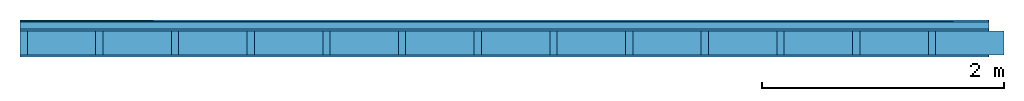
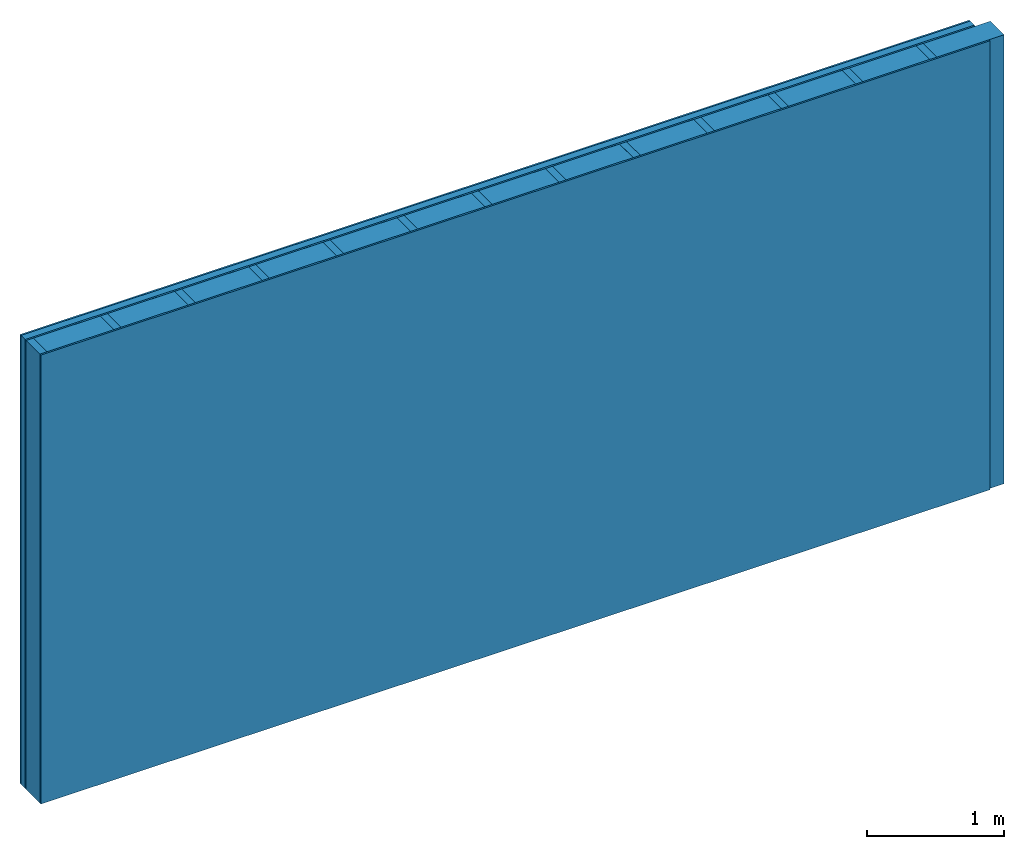
# One storey: 4 plates, 2 members, 1 element without a shape of its own.
"""IFC4 building model written with IfcOpenShell, lengths in metres."""

from ifc_helpers import new_model, si_unit, derived_unit, direction, frame, frame_2d, origin, origin_with_axes, place, context, project, spatial, rectangle, extrude, material, layer, layer_set, type_object, element, aggregate, save


model = new_model("IFC4")

# Units and contexts
plan_context = context("Plan", 3, precision=1e-05, world=origin(), true_north=direction((0.0, 1.0)))
model_context = context("Model", 3, precision=1e-05, world=origin(), true_north=direction((0.0, 1.0)))
ifc_project = project(units=[si_unit("LENGTHUNIT", "METRE"), derived_unit("SOUNDPRESSUREUNIT", [(si_unit("PRESSUREUNIT", "PASCAL", prefix="MICRO"), 0)]), si_unit("ENERGYUNIT", "JOULE", prefix="MEGA"), si_unit("MASSUNIT", "GRAM", prefix="KILO"), derived_unit("THERMALTRANSMITTANCEUNIT", [(si_unit("POWERUNIT", "WATT"), 1), (si_unit("AREAUNIT", "SQUARE_METRE"), -1), (si_unit("THERMODYNAMICTEMPERATUREUNIT", "KELVIN"), -1)]), derived_unit("AREADENSITYUNIT", [(si_unit("MASSUNIT", "GRAM", prefix="KILO"), 1), (si_unit("AREAUNIT", "SQUARE_METRE"), -1)]), derived_unit("USERDEFINED", [(si_unit("ENERGYUNIT", "JOULE", prefix="MEGA"), 1), (si_unit("AREAUNIT", "SQUARE_METRE"), -1)])], contexts=[plan_context, model_context])

# Site, building, storey
site = spatial("IfcSite", under=ifc_project)
building_placement = place(None, origin())
building = spatial("IfcBuilding", under=site, at=building_placement)
storey_placement = place(building_placement, origin())
storey = spatial("IfcBuildingStorey", under=building, at=storey_placement)

# Wall, members, plates
ifc_material_1 = material(Category="04.011")
ifc_layer_1 = layer(ifc_material_1, 0.015, Name="Surface 1")
ifc_material_2 = material(Category="10.008")
ifc_layer_2 = layer(ifc_material_2, 0.06, Name="outside 2nd layer")
ifc_material_3 = material(Category="03.007")
ifc_layer_3 = layer(ifc_material_3, 0.015, Name="outside 1st layer")
ifc_material_4 = material(Name="of the art")
ifc_layer_4 = layer(ifc_material_4, 0.0, Name="Bond")
ifc_layer_5 = layer(None, 0.2, Name="Support")
ifc_layer_6 = layer(ifc_material_4, 0.0, Name="Bond")
ifc_layer_7 = layer(ifc_material_3, 0.015, Name="1st layer")
ifc_material_5 = material(Name="Glued joints")
ifc_layer_8 = layer(ifc_material_5, 0.0, Name="Surface")
ifc_layer_set = layer_set([ifc_layer_1, ifc_layer_2, ifc_layer_3, ifc_layer_4, ifc_layer_5, ifc_layer_6, ifc_layer_7, ifc_layer_8])
wall_type = type_object("IfcWallType", Name="D0459", PredefinedType="NOTDEFINED", material=ifc_layer_set)
wall_placement = place(None, frame((0.0, 0.0, 0.0), z_axis=(0.0, -1.0, 0.0), x_axis=(1.0, 0.0, 0.0)))
wall = element("IfcWall", 1, at=wall_placement, inside=storey, type_object=wall_type, material=ifc_layer_set, Name="Wall #1")
ifc_material_6 = material()
member_1_placement = place(wall_placement, origin())
member_1 = element("IfcMember", 2, at=member_1_placement, material=ifc_material_6, Name="Support", context=plan_context, shape_type="SweptSolid", body=[
    extrude(rectangle(XDim=0.06, YDim=0.2, at=frame_2d((0.03, 0.1), x_axis=(1.0, 0.0))), frame((0.0, 4.0, 0.09), z_axis=(0.0, -1.0, 0.0), x_axis=(1.0, 0.0, 0.0)), (0.0, 0.0, 1.0), 4.0),
    extrude(rectangle(XDim=0.06, YDim=0.2, at=frame_2d((0.03, 0.1), x_axis=(1.0, 0.0))), frame((0.625, 4.0, 0.09), z_axis=(0.0, -1.0, 0.0), x_axis=(1.0, 0.0, 0.0)), (0.0, 0.0, 1.0), 4.0),
    extrude(rectangle(XDim=0.06, YDim=0.2, at=frame_2d((0.03, 0.1), x_axis=(1.0, 0.0))), frame((1.25, 4.0, 0.09), z_axis=(0.0, -1.0, 0.0), x_axis=(1.0, 0.0, 0.0)), (0.0, 0.0, 1.0), 4.0),
    extrude(rectangle(XDim=0.06, YDim=0.2, at=frame_2d((0.03, 0.1), x_axis=(1.0, 0.0))), frame((1.875, 4.0, 0.09), z_axis=(0.0, -1.0, 0.0), x_axis=(1.0, 0.0, 0.0)), (0.0, 0.0, 1.0), 4.0),
    extrude(rectangle(XDim=0.06, YDim=0.2, at=frame_2d((0.03, 0.1), x_axis=(1.0, 0.0))), frame((2.5, 4.0, 0.09), z_axis=(0.0, -1.0, 0.0), x_axis=(1.0, 0.0, 0.0)), (0.0, 0.0, 1.0), 4.0),
    extrude(rectangle(XDim=0.06, YDim=0.2, at=frame_2d((0.03, 0.1), x_axis=(1.0, 0.0))), frame((3.125, 4.0, 0.09), z_axis=(0.0, -1.0, 0.0), x_axis=(1.0, 0.0, 0.0)), (0.0, 0.0, 1.0), 4.0),
    extrude(rectangle(XDim=0.06, YDim=0.2, at=frame_2d((0.03, 0.1), x_axis=(1.0, 0.0))), frame((3.75, 4.0, 0.09), z_axis=(0.0, -1.0, 0.0), x_axis=(1.0, 0.0, 0.0)), (0.0, 0.0, 1.0), 4.0),
    extrude(rectangle(XDim=0.06, YDim=0.2, at=frame_2d((0.03, 0.1), x_axis=(1.0, 0.0))), frame((4.375, 4.0, 0.09), z_axis=(0.0, -1.0, 0.0), x_axis=(1.0, 0.0, 0.0)), (0.0, 0.0, 1.0), 4.0),
    extrude(rectangle(XDim=0.06, YDim=0.2, at=frame_2d((0.03, 0.1), x_axis=(1.0, 0.0))), frame((5.0, 4.0, 0.09), z_axis=(0.0, -1.0, 0.0), x_axis=(1.0, 0.0, 0.0)), (0.0, 0.0, 1.0), 4.0),
    extrude(rectangle(XDim=0.06, YDim=0.2, at=frame_2d((0.03, 0.1), x_axis=(1.0, 0.0))), frame((5.625, 4.0, 0.09), z_axis=(0.0, -1.0, 0.0), x_axis=(1.0, 0.0, 0.0)), (0.0, 0.0, 1.0), 4.0),
    extrude(rectangle(XDim=0.06, YDim=0.2, at=frame_2d((0.03, 0.1), x_axis=(1.0, 0.0))), frame((6.25, 4.0, 0.09), z_axis=(0.0, -1.0, 0.0), x_axis=(1.0, 0.0, 0.0)), (0.0, 0.0, 1.0), 4.0),
    extrude(rectangle(XDim=0.06, YDim=0.2, at=frame_2d((0.03, 0.1), x_axis=(1.0, 0.0))), frame((6.875, 4.0, 0.09), z_axis=(0.0, -1.0, 0.0), x_axis=(1.0, 0.0, 0.0)), (0.0, 0.0, 1.0), 4.0),
    extrude(rectangle(XDim=0.06, YDim=0.2, at=frame_2d((0.03, 0.1), x_axis=(1.0, 0.0))), frame((7.5, 4.0, 0.09), z_axis=(0.0, -1.0, 0.0), x_axis=(1.0, 0.0, 0.0)), (0.0, 0.0, 1.0), 4.0),
])
ifc_material_7 = material()
member_2_placement = place(wall_placement, origin())
member_2 = element("IfcMember", 3, at=member_2_placement, material=ifc_material_7, Name="Cavity", context=plan_context, shape_type="SweptSolid", body=[
    extrude(rectangle(XDim=0.565, YDim=0.2, at=frame_2d((0.2825, 0.1), x_axis=(1.0, 0.0))), frame((0.06, 4.0, 0.09), z_axis=(0.0, -1.0, 0.0), x_axis=(1.0, 0.0, 0.0)), (0.0, 0.0, 1.0), 4.0),
    extrude(rectangle(XDim=0.565, YDim=0.2, at=frame_2d((0.2825, 0.1), x_axis=(1.0, 0.0))), frame((0.685, 4.0, 0.09), z_axis=(0.0, -1.0, 0.0), x_axis=(1.0, 0.0, 0.0)), (0.0, 0.0, 1.0), 4.0),
    extrude(rectangle(XDim=0.565, YDim=0.2, at=frame_2d((0.2825, 0.1), x_axis=(1.0, 0.0))), frame((1.31, 4.0, 0.09), z_axis=(0.0, -1.0, 0.0), x_axis=(1.0, 0.0, 0.0)), (0.0, 0.0, 1.0), 4.0),
    extrude(rectangle(XDim=0.565, YDim=0.2, at=frame_2d((0.2825, 0.1), x_axis=(1.0, 0.0))), frame((1.935, 4.0, 0.09), z_axis=(0.0, -1.0, 0.0), x_axis=(1.0, 0.0, 0.0)), (0.0, 0.0, 1.0), 4.0),
    extrude(rectangle(XDim=0.565, YDim=0.2, at=frame_2d((0.2825, 0.1), x_axis=(1.0, 0.0))), frame((2.56, 4.0, 0.09), z_axis=(0.0, -1.0, 0.0), x_axis=(1.0, 0.0, 0.0)), (0.0, 0.0, 1.0), 4.0),
    extrude(rectangle(XDim=0.565, YDim=0.2, at=frame_2d((0.2825, 0.1), x_axis=(1.0, 0.0))), frame((3.185, 4.0, 0.09), z_axis=(0.0, -1.0, 0.0), x_axis=(1.0, 0.0, 0.0)), (0.0, 0.0, 1.0), 4.0),
    extrude(rectangle(XDim=0.565, YDim=0.2, at=frame_2d((0.2825, 0.1), x_axis=(1.0, 0.0))), frame((3.81, 4.0, 0.09), z_axis=(0.0, -1.0, 0.0), x_axis=(1.0, 0.0, 0.0)), (0.0, 0.0, 1.0), 4.0),
    extrude(rectangle(XDim=0.565, YDim=0.2, at=frame_2d((0.2825, 0.1), x_axis=(1.0, 0.0))), frame((4.435, 4.0, 0.09), z_axis=(0.0, -1.0, 0.0), x_axis=(1.0, 0.0, 0.0)), (0.0, 0.0, 1.0), 4.0),
    extrude(rectangle(XDim=0.565, YDim=0.2, at=frame_2d((0.2825, 0.1), x_axis=(1.0, 0.0))), frame((5.06, 4.0, 0.09), z_axis=(0.0, -1.0, 0.0), x_axis=(1.0, 0.0, 0.0)), (0.0, 0.0, 1.0), 4.0),
    extrude(rectangle(XDim=0.565, YDim=0.2, at=frame_2d((0.2825, 0.1), x_axis=(1.0, 0.0))), frame((5.685, 4.0, 0.09), z_axis=(0.0, -1.0, 0.0), x_axis=(1.0, 0.0, 0.0)), (0.0, 0.0, 1.0), 4.0),
    extrude(rectangle(XDim=0.565, YDim=0.2, at=frame_2d((0.2825, 0.1), x_axis=(1.0, 0.0))), frame((6.31, 4.0, 0.09), z_axis=(0.0, -1.0, 0.0), x_axis=(1.0, 0.0, 0.0)), (0.0, 0.0, 1.0), 4.0),
    extrude(rectangle(XDim=0.565, YDim=0.2, at=frame_2d((0.2825, 0.1), x_axis=(1.0, 0.0))), frame((6.935, 4.0, 0.09), z_axis=(0.0, -1.0, 0.0), x_axis=(1.0, 0.0, 0.0)), (0.0, 0.0, 1.0), 4.0),
    extrude(rectangle(XDim=0.565, YDim=0.2, at=frame_2d((0.2825, 0.1), x_axis=(1.0, 0.0))), frame((7.56, 4.0, 0.09), z_axis=(0.0, -1.0, 0.0), x_axis=(1.0, 0.0, 0.0)), (0.0, 0.0, 1.0), 4.0),
])
plate_1_placement = place(wall_placement, origin())
plate_1 = element("IfcPlate", 4, at=plate_1_placement, material=ifc_material_1, Name="Surface 1", context=plan_context, shape_type="SweptSolid", body=[
    extrude(rectangle(XDim=8.0, YDim=4.0, at=frame_2d((4.0, 2.0), x_axis=(1.0, 0.0))), origin_with_axes(), (0.0, 0.0, 1.0), 0.015),
])
plate_2_placement = place(wall_placement, origin())
plate_2 = element("IfcPlate", 5, at=plate_2_placement, material=ifc_material_2, Name="outside 2nd layer", context=plan_context, shape_type="SweptSolid", body=[
    extrude(rectangle(XDim=8.0, YDim=4.0, at=frame_2d((4.0, 2.0), x_axis=(1.0, 0.0))), frame((0.0, 0.0, 0.015), z_axis=(0.0, 0.0, 1.0), x_axis=(1.0, 0.0, 0.0)), (0.0, 0.0, 1.0), 0.06),
])
plate_3_placement = place(wall_placement, origin())
plate_3 = element("IfcPlate", 6, at=plate_3_placement, material=ifc_material_3, Name="outside 1st layer", context=plan_context, shape_type="SweptSolid", body=[
    extrude(rectangle(XDim=8.0, YDim=4.0, at=frame_2d((4.0, 2.0), x_axis=(1.0, 0.0))), frame((0.0, 0.0, 0.075), z_axis=(0.0, 0.0, 1.0), x_axis=(1.0, 0.0, 0.0)), (0.0, 0.0, 1.0), 0.015),
])
plate_4_placement = place(wall_placement, origin())
plate_4 = element("IfcPlate", 7, at=plate_4_placement, material=ifc_material_3, Name="1st layer", context=plan_context, shape_type="SweptSolid", body=[
    extrude(rectangle(XDim=8.0, YDim=4.0, at=frame_2d((4.0, 2.0), x_axis=(1.0, 0.0))), frame((0.0, 0.0, 0.29), z_axis=(0.0, 0.0, 1.0), x_axis=(1.0, 0.0, 0.0)), (0.0, 0.0, 1.0), 0.015),
])
aggregate(wall, [plate_1, plate_2, plate_3, member_1, member_2, plate_4])

save(model, "model.ifc")
